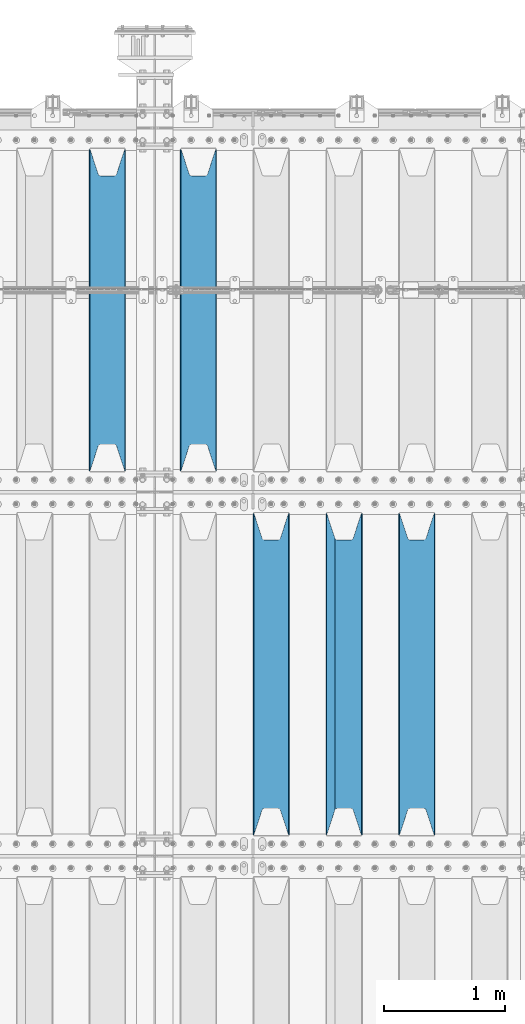
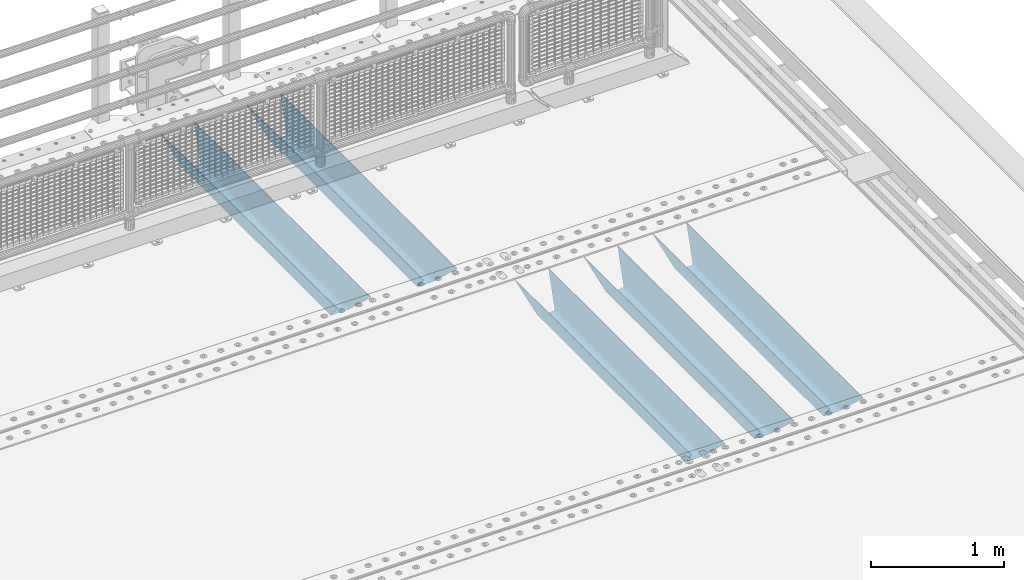
# One storey, part 123 of 240: 5 beams.
"""IFC2X3 building model written with IfcOpenShell, lengths in millimetres."""

import ifcopenshell
import ifcopenshell.guid

model = None  # the IFC model being written
_history = None  # IfcOwnerHistory: only IFC2X3 demands one
_inside = {}  # id of a spatial element -> (the spatial element, [elements in it])
_under = {}  # id of a project, library or spatial element -> (it, [spatial elements below it])
_declared = {}  # id of a project -> (the project, [libraries it declares])
_typed = {}  # id of a type object -> (the type object, [elements of that type])
_made_of = {}  # id of a material, layer set ... -> (it, [elements and type objects made of it])


def new_model(schema):
    """Start an empty IFC model of exactly this schema.

    Asked for "IFC4X3", IfcOpenShell would pick the latest addendum, in which some entities
    have other attributes; the version numbers below select the first issue.
    IFC2X3 requires an IfcOwnerHistory on every rooted entity: one is made here for all.
    """
    global model, _history
    if schema == "IFC4X3":
        model = ifcopenshell.file(schema_version=(4, 3, 0, 0))
    else:
        model = ifcopenshell.file(schema=schema)
    _inside.clear()
    _under.clear()
    _declared.clear()
    _typed.clear()
    _made_of.clear()
    _history = None
    if model.schema == "IFC2X3":
        org = make("IfcOrganization", Name="unknown")
        user = make(
            "IfcPersonAndOrganization",
            ThePerson=make("IfcPerson", FamilyName="unknown"),
            TheOrganization=org,
        )
        app = make(
            "IfcApplication",
            ApplicationDeveloper=org,
            Version="unknown",
            ApplicationFullName="unknown",
            ApplicationIdentifier="unknown",
        )
        _history = make(
            "IfcOwnerHistory",
            OwningUser=user,
            OwningApplication=app,
            ChangeAction="ADDED",
            CreationDate=0,
        )
    return model


def make(cls, **values):
    """One entity of the class cls with the attributes given. An attribute that is None is left unset."""
    return model.create_entity(
        cls, **{name: value for name, value in values.items() if value is not None}
    )


def rooted(cls, **values):
    """An entity with a GlobalId (a new one), such as an element, a storey or a relation."""
    return make(cls, GlobalId=ifcopenshell.guid.new(), OwnerHistory=_history, **values)


def si_unit(unit_type, name, prefix=None):
    """IfcSIUnit, for example si_unit("LENGTHUNIT", "METRE", prefix="MILLI")."""
    return make("IfcSIUnit", UnitType=unit_type, Prefix=prefix, Name=name)


def assignment(units):
    """IfcUnitAssignment: the units of a project."""
    return None if units is None else make("IfcUnitAssignment", Units=units)


def point(xyz):
    """IfcCartesianPoint."""
    return None if xyz is None else make("IfcCartesianPoint", Coordinates=xyz)


def direction(xyz):
    """IfcDirection."""
    return None if xyz is None else make("IfcDirection", DirectionRatios=xyz)


def frame(location, z_axis=None, x_axis=None):
    """IfcAxis2Placement3D, a coordinate frame: its origin and axes. An axis left out is left unset."""
    return make(
        "IfcAxis2Placement3D",
        Location=point(location),
        Axis=direction(z_axis),
        RefDirection=direction(x_axis),
    )


def origin_with_axes():
    """The frame at (0, 0, 0) with the z axis (0, 0, 1) and the x axis (1, 0, 0) written out."""
    return frame((0.0, 0.0, 0.0), z_axis=(0.0, 0.0, 1.0), x_axis=(1.0, 0.0, 0.0))


def place(relative_to, where):
    """IfcLocalPlacement: puts the frame where relative to a parent placement (None: the world)."""
    return make(
        "IfcLocalPlacement", PlacementRelTo=relative_to, RelativePlacement=where
    )


def context(
    kind, dimensions, precision=None, world=None, true_north=None, identifier=None
):
    """IfcGeometricRepresentationContext, for example the 3D "Model" context."""
    return make(
        "IfcGeometricRepresentationContext",
        ContextIdentifier=identifier,
        ContextType=kind,
        CoordinateSpaceDimension=dimensions,
        Precision=precision,
        WorldCoordinateSystem=world,
        TrueNorth=true_north,
    )


def subcontext(parent, identifier, kind, view, scale=None):
    """IfcGeometricRepresentationSubContext, for example "Body" below "Model"."""
    return make(
        "IfcGeometricRepresentationSubContext",
        ContextIdentifier=identifier,
        ContextType=kind,
        ParentContext=parent,
        TargetScale=scale,
        TargetView=view,
    )


def project(units=None, contexts=None):
    """IfcProject with its units and contexts."""
    return rooted(
        "IfcProject",
        Name="project",
        RepresentationContexts=contexts,
        UnitsInContext=assignment(units),
    )


def spatial(cls, under=None, at=None, **own):
    """A site, building, storey or space (cls), placed at a placement, below another one or the project."""
    s = rooted(cls, ObjectPlacement=at, **own)
    if under is not None:
        _under.setdefault(under.id(), (under, []))[1].append(s)
    return s


def faces_of(points, faces, orient=None, outer=None):
    """IfcFace entities. A face is a list of loops; a loop is a list of indices into points, from 0.

    orient and outer hold one flag for each loop. By default every Orientation is true, the
    first loop of a face is its IfcFaceOuterBound and the others are IfcFaceBound.
    """
    made = []
    for i, loops in enumerate(faces):
        bounds = []
        for j, loop in enumerate(loops):
            is_outer = j == 0 if outer is None else outer[i][j]
            bounds.append(
                make(
                    "IfcFaceOuterBound" if is_outer else "IfcFaceBound",
                    Bound=make("IfcPolyLoop", Polygon=[points[k] for k in loop]),
                    Orientation=True if orient is None else orient[i][j],
                )
            )
        made.append(make("IfcFace", Bounds=bounds))
    return made


def faceted_brep(points, faces, orient=None, outer=None, voids=None):
    """IfcFacetedBrep: a solid bounded by flat faces; with voids (closed shells), ...WithVoids."""
    shared = [point(p) for p in points]
    hull = make("IfcClosedShell", CfsFaces=faces_of(shared, faces, orient, outer))
    if voids is None:
        return make("IfcFacetedBrep", Outer=hull)
    return make(
        "IfcFacetedBrepWithVoids",
        Outer=hull,
        Voids=[
            make(cls, CfsFaces=faces_of(shared, fs, o, b)) for cls, fs, o, b in voids
        ],
    )


def shape(context_of_items, identifier, shape_type, items):
    """IfcShapeRepresentation: the items that make up one representation, for example the "Body"."""
    return make(
        "IfcShapeRepresentation",
        ContextOfItems=context_of_items,
        RepresentationIdentifier=identifier,
        RepresentationType=shape_type,
        Items=items,
    )


def material(Name=None, Category=None):
    """IfcMaterial."""
    return make("IfcMaterial", Name=Name, Category=Category)


def made_of(thing, what):
    """Note that an element or type object is made of a material, layer set ...; save() writes the relation."""
    if what is not None:
        _made_of.setdefault(what.id(), (what, []))[1].append(thing)
    return thing


def type_object(cls, material=None, **own):
    """A type object (cls), such as IfcWallType, which elements share."""
    return made_of(rooted(cls, **own), material)


def element(
    cls,
    number,
    at=None,
    inside=None,
    cuts=None,
    type_object=None,
    material=None,
    context=None,
    identifier="Body",
    shape_type=None,
    held_by="IfcProductDefinitionShape",
    body=None,
    shapes=None,
    **own,
):
    """One element of the class cls, such as IfcWall. Its Tag is "e" and its number.

    at: its placement. inside: the storey or other place that contains it. cuts: it is an
    opening in that element (IfcRelVoidsElement). A single representation is given by context,
    identifier, shape_type and body (its items); several are given by shapes. held_by: the class
    of the entity that holds the representations. save() writes the other relations.
    """
    e = rooted(cls, Tag="e%d" % number, ObjectPlacement=at, **own)
    if body is not None:
        shapes = [shape(context, identifier, shape_type, body)]
    if shapes is not None:
        e.Representation = make(held_by, Representations=shapes)
    if inside is not None:
        _inside.setdefault(inside.id(), (inside, []))[1].append(e)
    if cuts is not None:
        rooted(
            "IfcRelVoidsElement", RelatingBuildingElement=cuts, RelatedOpeningElement=e
        )
    if type_object is not None:
        _typed.setdefault(type_object.id(), (type_object, []))[1].append(e)
    return made_of(e, material)


def aggregate(whole, parts):
    """IfcRelAggregates: a whole, such as a stair, and the parts it consists of."""
    return rooted("IfcRelAggregates", RelatingObject=whole, RelatedObjects=parts)


def save(model, path):
    """Write the relations noted so far, then the file.

    IfcRelAggregates (storeys below a building ...), IfcRelContainedInSpatialStructure (elements
    in a storey), IfcRelDefinesByType, IfcRelAssociatesMaterial and IfcRelDeclares: one each for
    every whole, place, type object, material and project.
    """
    for whole, parts in _under.values():
        aggregate(whole, parts)
    for where, things in _inside.values():
        rooted(
            "IfcRelContainedInSpatialStructure",
            RelatedElements=things,
            RelatingStructure=where,
        )
    for kind, things in _typed.values():
        rooted("IfcRelDefinesByType", RelatedObjects=things, RelatingType=kind)
    for what, things in _made_of.values():
        rooted("IfcRelAssociatesMaterial", RelatedObjects=things, RelatingMaterial=what)
    for by, libraries in _declared.values():
        rooted("IfcRelDeclares", RelatingContext=by, RelatedDefinitions=libraries)
    model.write(path)


model = new_model("IFC2X3")

# Units and contexts
model_context = context("Model", 3, precision=1e-05, world=origin_with_axes())
body_context = subcontext(model_context, "Body", "Model", "MODEL_VIEW")
ifc_project = project(units=[si_unit("LENGTHUNIT", "METRE", prefix="MILLI"), si_unit("AREAUNIT", "SQUARE_METRE"), si_unit("VOLUMEUNIT", "CUBIC_METRE"), si_unit("MASSUNIT", "GRAM", prefix="KILO"), si_unit("TIMEUNIT", "SECOND"), si_unit("PLANEANGLEUNIT", "RADIAN"), si_unit("SOLIDANGLEUNIT", "STERADIAN"), si_unit("THERMODYNAMICTEMPERATUREUNIT", "DEGREE_CELSIUS"), si_unit("LUMINOUSINTENSITYUNIT", "LUMEN")], contexts=[model_context])

# Site, building, storey
site_placement = place(None, origin_with_axes())
site = spatial("IfcSite", under=ifc_project, at=site_placement, CompositionType="ELEMENT")
building_placement = place(site_placement, origin_with_axes())
building = spatial("IfcBuilding", under=site, at=building_placement, Name="Standard", CompositionType="ELEMENT")
storey_placement = place(building_placement, origin_with_axes())
storey = spatial("IfcBuildingStorey", under=building, at=storey_placement, Name="Undefined", CompositionType="ELEMENT", Elevation=0.0)

# Beams
ifc_material = material(Name="STEEL/S355N")
beam_type = type_object("IfcBeamType", PredefinedType="NOTDEFINED")
beam_1_placement = place(storey_placement, frame((55000.0, 30175.0, -115.0), z_axis=(0.0, 0.0, 1.0), x_axis=(0.0, 1.0, 0.0)))
element("IfcBeam", 1, at=beam_1_placement, inside=storey, type_object=beam_type, material=ifc_material, context=body_context, shape_type="Brep", body=[
    faceted_brep([(0.0, 150.0, 115.0), (0.0, 143.690000000002, 115.0), (2650.00000000297, 143.690000000002, 115.0), (2650.00000000297, 150.0, 115.0), (2650.00000000297, 142.059565218406, 110.000000003094), (2650.00000000297, 148.369565218403, 110.000000003094), (2441.90079219209, -80.1103600731149, -98.0992078077845), (2437.7588105432, -77.5672621345584, -102.241189456673), (2434.06523489747, -74.4080125315522, -105.934765102404), (2430.9108609509, -70.7102721255724, -109.089139048974), (2428.37322971128, -66.5649389910031, -111.626770288588), (2426.51472138055, -62.0739139532889, -113.485278619323), (2425.38102192092, -57.3475956567636, -114.618978078955), (2424.99999999987, -52.5021667386536, -115.0), (2424.99999999987, 52.5021667386536, -115.0), (2425.38102192092, 57.3475956567636, -114.618978078955), (2426.51472138055, 62.0739139532889, -113.485278619323), (2428.37322971128, 66.5649389910031, -111.626770288588), (2430.9108609509, 70.7102721255724, -109.089139048974), (2434.06523489747, 74.4080125315522, -105.934765102404), (2437.7588105432, 77.5672621345584, -102.241189456673), (2441.90079219209, 80.1103600731149, -98.0992078077846), (2446.38936140512, 81.9747917625791, -93.6106385947584), (2448.2494850041, 76.2713538057287, -91.7505149957729), (2444.62967112263, 74.76777986261, -95.3703288772456), (2441.28936334127, 72.7168944282894, -98.710636658607), (2438.31067330439, 70.1691124903809, -101.689326695487), (2435.76682334748, 67.1870637758839, -104.233176652398), (2433.72034654134, 63.8440531834931, -106.279653458539), (2432.22154950042, 60.2222587982324, -107.778450499454), (2431.30727574265, 56.4107117849126, -108.692724257221), (2430.99999999987, 52.5031078186876, -109.0), (2430.99999999987, -52.5031078186876, -109.0), (2431.30727574265, -56.4107117849126, -108.692724257221), (2432.22154950042, -60.2222587982324, -107.778450499454), (2433.72034654134, -63.8440531834931, -106.279653458539), (2435.76682334748, -67.1870637758839, -104.233176652398), (2438.31067330439, -70.1691124903809, -101.689326695487), (2441.28936334127, -72.7168944282894, -98.7106366586071), (2444.62967112263, -74.76777986261, -95.3703288772457), (2448.2494850041, -76.2713538057287, -91.7505149957729), (2650.00000000297, -142.059565218406, 110.000000003094), (2650.00000000297, -148.369565218403, 110.000000003094), (2446.38936140512, -81.9747917625791, -93.6106385947584), (2650.00000000297, -143.690000000002, 115.0), (2650.00000000297, -150.0, 115.0), (0.0, -143.690000000002, 115.0), (0.0, -150.0, 115.0), (0.0, -148.369565218258, 110.000000002667), (203.610638597427, -81.9747917625791, -93.6106385947584), (208.09920781045, -80.1103600731149, -98.0992078077845), (212.241189459342, -77.5672621345584, -102.241189456673), (215.93476510507, -74.4080125315522, -105.934765102404), (219.089139051641, -70.7102721255724, -109.089139048974), (221.626770291256, -66.5649389910031, -111.626770288588), (223.485278621989, -62.0739139532889, -113.485278619323), (224.618978081624, -57.3475956567636, -114.618978078955), (225.000000002663, -52.5021667386536, -115.0), (225.000000002663, 52.5021667386536, -115.0), (224.618978081624, 57.3475956567636, -114.618978078955), (223.485278621989, 62.0739139532889, -113.485278619323), (221.626770291256, 66.5649389910031, -111.626770288588), (219.089139051641, 70.7102721255724, -109.089139048974), (215.93476510507, 74.4080125315522, -105.934765102404), (212.241189459342, 77.5672621345584, -102.241189456673), (208.09920781045, 80.1103600731149, -98.0992078077846), (203.610638597427, 81.9747917625791, -93.6106385947584), (0.0, 148.369565218258, 110.000000002667), (0.0, 142.05956521826, 110.000000002667), (201.750514998439, 76.2713538057287, -91.7505149957729), (205.370328879908, 74.76777986261, -95.3703288772456), (208.710636661275, 72.7168944282894, -98.710636658607), (211.689326698153, 70.1691124903809, -101.689326695487), (214.233176655063, 67.1870637758839, -104.233176652398), (216.279653461206, 63.8440531834931, -106.279653458539), (217.778450502123, 60.2222587982324, -107.778450499454), (218.692724259887, 56.4107117849126, -108.692724257221), (219.000000002667, 52.5031078186876, -109.0), (219.000000002667, -52.5031078186876, -109.0), (218.692724259887, -56.4107117849126, -108.692724257221), (217.778450502123, -60.2222587982324, -107.778450499454), (216.279653461206, -63.8440531834931, -106.279653458539), (214.233176655063, -67.1870637758839, -104.233176652398), (211.689326698153, -70.1691124903809, -101.689326695487), (208.710636661275, -72.7168944282894, -98.7106366586071), (205.370328879915, -74.76777986261, -95.3703288772457), (201.750514998439, -76.2713538057287, -91.7505149957729), (0.0, -142.05956521826, 110.000000002667)], [[[0, 1, 2, 3]], [[3, 2, 4, 5]], [[6, 7, 8, 9, 10, 11, 12, 13, 14, 15, 16, 17, 18, 19, 20, 21, 22, 5, 4, 23, 24, 25, 26, 27, 28, 29, 30, 31, 32, 33, 34, 35, 36, 37, 38, 39, 40, 41, 42, 43]], [[44, 45, 42, 41]], [[46, 47, 45, 44]], [[43, 42, 45, 47, 48, 49]], [[6, 43, 49, 50]], [[7, 6, 50, 51]], [[8, 7, 51, 52]], [[9, 8, 52, 53]], [[10, 9, 53, 54]], [[11, 10, 54, 55]], [[12, 11, 55, 56]], [[13, 12, 56, 57]], [[14, 13, 57, 58]], [[15, 14, 58, 59]], [[16, 15, 59, 60]], [[17, 16, 60, 61]], [[18, 17, 61, 62]], [[19, 18, 62, 63]], [[20, 19, 63, 64]], [[21, 20, 64, 65]], [[22, 21, 65, 66]], [[0, 3, 5, 22, 66, 67]], [[1, 0, 67, 68]], [[23, 4, 2, 1, 68, 69]], [[24, 23, 69, 70]], [[25, 24, 70, 71]], [[26, 25, 71, 72]], [[27, 26, 72, 73]], [[28, 27, 73, 74]], [[29, 28, 74, 75]], [[30, 29, 75, 76]], [[31, 30, 76, 77]], [[32, 31, 77, 78]], [[33, 32, 78, 79]], [[34, 33, 79, 80]], [[35, 34, 80, 81]], [[36, 35, 81, 82]], [[37, 36, 82, 83]], [[38, 37, 83, 84]], [[39, 38, 84, 85]], [[40, 39, 85, 86]], [[46, 44, 41, 40, 86, 87]], [[47, 46, 87, 48]], [[86, 85, 84, 83, 82, 81, 80, 79, 78, 77, 76, 75, 74, 73, 72, 71, 70, 69, 68, 67, 66, 65, 64, 63, 62, 61, 60, 59, 58, 57, 56, 55, 54, 53, 52, 51, 50, 49, 48, 87]]]),
])
beam_2_placement = place(storey_placement, frame((54400.0, 30175.0, -115.0), z_axis=(0.0, 0.0, 1.0), x_axis=(0.0, 1.0, 0.0)))
element("IfcBeam", 2, at=beam_2_placement, inside=storey, type_object=beam_type, material=ifc_material, context=body_context, shape_type="Brep", body=[
    faceted_brep([(0.0, 150.0, 115.0), (0.0, 143.690000000002, 115.0), (2650.00000000297, 143.690000000002, 115.0), (2650.00000000297, 150.0, 115.0), (2650.00000000297, 142.059565218406, 110.000000003094), (2650.00000000297, 148.369565218403, 110.000000003094), (2441.90079219209, -80.1103600731149, -98.0992078077845), (2437.7588105432, -77.5672621345584, -102.241189456673), (2434.06523489747, -74.4080125315522, -105.934765102404), (2430.9108609509, -70.7102721255724, -109.089139048974), (2428.37322971128, -66.5649389910031, -111.626770288588), (2426.51472138055, -62.0739139532889, -113.485278619323), (2425.38102192092, -57.3475956567636, -114.618978078955), (2424.99999999987, -52.5021667386536, -115.0), (2424.99999999987, 52.5021667386536, -115.0), (2425.38102192092, 57.3475956567636, -114.618978078955), (2426.51472138055, 62.0739139532889, -113.485278619323), (2428.37322971128, 66.5649389910031, -111.626770288588), (2430.9108609509, 70.7102721255724, -109.089139048974), (2434.06523489747, 74.4080125315522, -105.934765102404), (2437.7588105432, 77.5672621345584, -102.241189456673), (2441.90079219209, 80.1103600731149, -98.0992078077846), (2446.38936140512, 81.9747917625791, -93.6106385947584), (2448.2494850041, 76.2713538057287, -91.7505149957729), (2444.62967112263, 74.76777986261, -95.3703288772456), (2441.28936334127, 72.7168944282894, -98.710636658607), (2438.31067330439, 70.1691124903809, -101.689326695487), (2435.76682334748, 67.1870637758839, -104.233176652398), (2433.72034654134, 63.8440531834931, -106.279653458539), (2432.22154950042, 60.2222587982324, -107.778450499454), (2431.30727574265, 56.4107117849126, -108.692724257221), (2430.99999999987, 52.5031078186876, -109.0), (2430.99999999987, -52.5031078186876, -109.0), (2431.30727574265, -56.4107117849126, -108.692724257221), (2432.22154950042, -60.2222587982324, -107.778450499454), (2433.72034654134, -63.8440531834931, -106.279653458539), (2435.76682334748, -67.1870637758839, -104.233176652398), (2438.31067330439, -70.1691124903809, -101.689326695487), (2441.28936334127, -72.7168944282894, -98.7106366586071), (2444.62967112263, -74.76777986261, -95.3703288772457), (2448.2494850041, -76.2713538057287, -91.7505149957729), (2650.00000000297, -142.059565218406, 110.000000003094), (2650.00000000297, -148.369565218403, 110.000000003094), (2446.38936140512, -81.9747917625791, -93.6106385947584), (2650.00000000297, -143.690000000002, 115.0), (2650.00000000297, -150.0, 115.0), (0.0, -143.690000000002, 115.0), (0.0, -150.0, 115.0), (0.0, -148.369565218258, 110.000000002667), (203.610638597427, -81.9747917625791, -93.6106385947584), (208.09920781045, -80.1103600731149, -98.0992078077845), (212.241189459342, -77.5672621345584, -102.241189456673), (215.93476510507, -74.4080125315522, -105.934765102404), (219.089139051641, -70.7102721255724, -109.089139048974), (221.626770291256, -66.5649389910031, -111.626770288588), (223.485278621989, -62.0739139532889, -113.485278619323), (224.618978081624, -57.3475956567636, -114.618978078955), (225.000000002663, -52.5021667386536, -115.0), (225.000000002663, 52.5021667386536, -115.0), (224.618978081624, 57.3475956567636, -114.618978078955), (223.485278621989, 62.0739139532889, -113.485278619323), (221.626770291256, 66.5649389910031, -111.626770288588), (219.089139051641, 70.7102721255724, -109.089139048974), (215.93476510507, 74.4080125315522, -105.934765102404), (212.241189459342, 77.5672621345584, -102.241189456673), (208.09920781045, 80.1103600731149, -98.0992078077846), (203.610638597427, 81.9747917625791, -93.6106385947584), (0.0, 148.369565218258, 110.000000002667), (0.0, 142.05956521826, 110.000000002667), (201.750514998439, 76.2713538057287, -91.7505149957729), (205.370328879908, 74.76777986261, -95.3703288772456), (208.710636661275, 72.7168944282894, -98.710636658607), (211.689326698153, 70.1691124903809, -101.689326695487), (214.233176655063, 67.1870637758839, -104.233176652398), (216.279653461206, 63.8440531834931, -106.279653458539), (217.778450502123, 60.2222587982324, -107.778450499454), (218.692724259887, 56.4107117849126, -108.692724257221), (219.000000002667, 52.5031078186876, -109.0), (219.000000002667, -52.5031078186876, -109.0), (218.692724259887, -56.4107117849126, -108.692724257221), (217.778450502123, -60.2222587982324, -107.778450499454), (216.279653461206, -63.8440531834931, -106.279653458539), (214.233176655063, -67.1870637758839, -104.233176652398), (211.689326698153, -70.1691124903809, -101.689326695487), (208.710636661275, -72.7168944282894, -98.7106366586071), (205.370328879915, -74.76777986261, -95.3703288772457), (201.750514998439, -76.2713538057287, -91.7505149957729), (0.0, -142.05956521826, 110.000000002667)], [[[0, 1, 2, 3]], [[3, 2, 4, 5]], [[6, 7, 8, 9, 10, 11, 12, 13, 14, 15, 16, 17, 18, 19, 20, 21, 22, 5, 4, 23, 24, 25, 26, 27, 28, 29, 30, 31, 32, 33, 34, 35, 36, 37, 38, 39, 40, 41, 42, 43]], [[44, 45, 42, 41]], [[46, 47, 45, 44]], [[43, 42, 45, 47, 48, 49]], [[6, 43, 49, 50]], [[7, 6, 50, 51]], [[8, 7, 51, 52]], [[9, 8, 52, 53]], [[10, 9, 53, 54]], [[11, 10, 54, 55]], [[12, 11, 55, 56]], [[13, 12, 56, 57]], [[14, 13, 57, 58]], [[15, 14, 58, 59]], [[16, 15, 59, 60]], [[17, 16, 60, 61]], [[18, 17, 61, 62]], [[19, 18, 62, 63]], [[20, 19, 63, 64]], [[21, 20, 64, 65]], [[22, 21, 65, 66]], [[0, 3, 5, 22, 66, 67]], [[1, 0, 67, 68]], [[23, 4, 2, 1, 68, 69]], [[24, 23, 69, 70]], [[25, 24, 70, 71]], [[26, 25, 71, 72]], [[27, 26, 72, 73]], [[28, 27, 73, 74]], [[29, 28, 74, 75]], [[30, 29, 75, 76]], [[31, 30, 76, 77]], [[32, 31, 77, 78]], [[33, 32, 78, 79]], [[34, 33, 79, 80]], [[35, 34, 80, 81]], [[36, 35, 81, 82]], [[37, 36, 82, 83]], [[38, 37, 83, 84]], [[39, 38, 84, 85]], [[40, 39, 85, 86]], [[46, 44, 41, 40, 86, 87]], [[47, 46, 87, 48]], [[86, 85, 84, 83, 82, 81, 80, 79, 78, 77, 76, 75, 74, 73, 72, 71, 70, 69, 68, 67, 66, 65, 64, 63, 62, 61, 60, 59, 58, 57, 56, 55, 54, 53, 52, 51, 50, 49, 48, 87]]]),
])
beam_3_placement = place(storey_placement, frame((53800.0, 30175.0, -115.0), z_axis=(0.0, 0.0, 1.0), x_axis=(0.0, 1.0, 0.0)))
element("IfcBeam", 3, at=beam_3_placement, inside=storey, type_object=beam_type, material=ifc_material, context=body_context, shape_type="Brep", body=[
    faceted_brep([(0.0, 150.0, 115.0), (0.0, 143.690000000002, 115.0), (2650.00000000297, 143.690000000002, 115.0), (2650.00000000297, 150.0, 115.0), (2650.00000000297, 142.059565218406, 110.000000003094), (2650.00000000297, 148.369565218403, 110.000000003094), (2441.90079219209, -80.1103600731149, -98.0992078077845), (2437.7588105432, -77.5672621345584, -102.241189456673), (2434.06523489747, -74.4080125315522, -105.934765102404), (2430.9108609509, -70.7102721255724, -109.089139048974), (2428.37322971128, -66.5649389910031, -111.626770288588), (2426.51472138055, -62.0739139532889, -113.485278619323), (2425.38102192092, -57.3475956567636, -114.618978078955), (2424.99999999987, -52.5021667386536, -115.0), (2424.99999999987, 52.5021667386536, -115.0), (2425.38102192092, 57.3475956567636, -114.618978078955), (2426.51472138055, 62.0739139532889, -113.485278619323), (2428.37322971128, 66.5649389910031, -111.626770288588), (2430.9108609509, 70.7102721255724, -109.089139048974), (2434.06523489747, 74.4080125315522, -105.934765102404), (2437.7588105432, 77.5672621345584, -102.241189456673), (2441.90079219209, 80.1103600731149, -98.0992078077846), (2446.38936140512, 81.9747917625791, -93.6106385947584), (2448.2494850041, 76.2713538057287, -91.7505149957729), (2444.62967112263, 74.76777986261, -95.3703288772456), (2441.28936334127, 72.7168944282894, -98.710636658607), (2438.31067330439, 70.1691124903809, -101.689326695487), (2435.76682334748, 67.1870637758839, -104.233176652398), (2433.72034654134, 63.8440531834931, -106.279653458539), (2432.22154950042, 60.2222587982324, -107.778450499454), (2431.30727574265, 56.4107117849126, -108.692724257221), (2430.99999999987, 52.5031078186876, -109.0), (2430.99999999987, -52.5031078186876, -109.0), (2431.30727574265, -56.4107117849126, -108.692724257221), (2432.22154950042, -60.2222587982324, -107.778450499454), (2433.72034654134, -63.8440531834931, -106.279653458539), (2435.76682334748, -67.1870637758839, -104.233176652398), (2438.31067330439, -70.1691124903809, -101.689326695487), (2441.28936334127, -72.7168944282894, -98.7106366586071), (2444.62967112263, -74.76777986261, -95.3703288772457), (2448.2494850041, -76.2713538057287, -91.7505149957729), (2650.00000000297, -142.059565218406, 110.000000003094), (2650.00000000297, -148.369565218403, 110.000000003094), (2446.38936140512, -81.9747917625791, -93.6106385947584), (2650.00000000297, -143.690000000002, 115.0), (2650.00000000297, -150.0, 115.0), (0.0, -143.690000000002, 115.0), (0.0, -150.0, 115.0), (0.0, -148.369565218258, 110.000000002667), (203.610638597427, -81.9747917625791, -93.6106385947584), (208.09920781045, -80.1103600731149, -98.0992078077845), (212.241189459342, -77.5672621345584, -102.241189456673), (215.93476510507, -74.4080125315522, -105.934765102404), (219.089139051641, -70.7102721255724, -109.089139048974), (221.626770291256, -66.5649389910031, -111.626770288588), (223.485278621989, -62.0739139532889, -113.485278619323), (224.618978081624, -57.3475956567636, -114.618978078955), (225.000000002663, -52.5021667386536, -115.0), (225.000000002663, 52.5021667386536, -115.0), (224.618978081624, 57.3475956567636, -114.618978078955), (223.485278621989, 62.0739139532889, -113.485278619323), (221.626770291256, 66.5649389910031, -111.626770288588), (219.089139051641, 70.7102721255724, -109.089139048974), (215.93476510507, 74.4080125315522, -105.934765102404), (212.241189459342, 77.5672621345584, -102.241189456673), (208.09920781045, 80.1103600731149, -98.0992078077846), (203.610638597427, 81.9747917625791, -93.6106385947584), (0.0, 148.369565218258, 110.000000002667), (0.0, 142.05956521826, 110.000000002667), (201.750514998439, 76.2713538057287, -91.7505149957729), (205.370328879908, 74.76777986261, -95.3703288772456), (208.710636661275, 72.7168944282894, -98.710636658607), (211.689326698153, 70.1691124903809, -101.689326695487), (214.233176655063, 67.1870637758839, -104.233176652398), (216.279653461206, 63.8440531834931, -106.279653458539), (217.778450502123, 60.2222587982324, -107.778450499454), (218.692724259887, 56.4107117849126, -108.692724257221), (219.000000002667, 52.5031078186876, -109.0), (219.000000002667, -52.5031078186876, -109.0), (218.692724259887, -56.4107117849126, -108.692724257221), (217.778450502123, -60.2222587982324, -107.778450499454), (216.279653461206, -63.8440531834931, -106.279653458539), (214.233176655063, -67.1870637758839, -104.233176652398), (211.689326698153, -70.1691124903809, -101.689326695487), (208.710636661275, -72.7168944282894, -98.7106366586071), (205.370328879915, -74.76777986261, -95.3703288772457), (201.750514998439, -76.2713538057287, -91.7505149957729), (0.0, -142.05956521826, 110.000000002667)], [[[0, 1, 2, 3]], [[3, 2, 4, 5]], [[6, 7, 8, 9, 10, 11, 12, 13, 14, 15, 16, 17, 18, 19, 20, 21, 22, 5, 4, 23, 24, 25, 26, 27, 28, 29, 30, 31, 32, 33, 34, 35, 36, 37, 38, 39, 40, 41, 42, 43]], [[44, 45, 42, 41]], [[46, 47, 45, 44]], [[43, 42, 45, 47, 48, 49]], [[6, 43, 49, 50]], [[7, 6, 50, 51]], [[8, 7, 51, 52]], [[9, 8, 52, 53]], [[10, 9, 53, 54]], [[11, 10, 54, 55]], [[12, 11, 55, 56]], [[13, 12, 56, 57]], [[14, 13, 57, 58]], [[15, 14, 58, 59]], [[16, 15, 59, 60]], [[17, 16, 60, 61]], [[18, 17, 61, 62]], [[19, 18, 62, 63]], [[20, 19, 63, 64]], [[21, 20, 64, 65]], [[22, 21, 65, 66]], [[0, 3, 5, 22, 66, 67]], [[1, 0, 67, 68]], [[23, 4, 2, 1, 68, 69]], [[24, 23, 69, 70]], [[25, 24, 70, 71]], [[26, 25, 71, 72]], [[27, 26, 72, 73]], [[28, 27, 73, 74]], [[29, 28, 74, 75]], [[30, 29, 75, 76]], [[31, 30, 76, 77]], [[32, 31, 77, 78]], [[33, 32, 78, 79]], [[34, 33, 79, 80]], [[35, 34, 80, 81]], [[36, 35, 81, 82]], [[37, 36, 82, 83]], [[38, 37, 83, 84]], [[39, 38, 84, 85]], [[40, 39, 85, 86]], [[46, 44, 41, 40, 86, 87]], [[47, 46, 87, 48]], [[86, 85, 84, 83, 82, 81, 80, 79, 78, 77, 76, 75, 74, 73, 72, 71, 70, 69, 68, 67, 66, 65, 64, 63, 62, 61, 60, 59, 58, 57, 56, 55, 54, 53, 52, 51, 50, 49, 48, 87]]]),
])
beam_4_placement = place(storey_placement, frame((53200.0, 33175.0, -115.0), z_axis=(0.0, 0.0, 1.0), x_axis=(0.0, 1.0, 0.0)))
element("IfcBeam", 4, at=beam_4_placement, inside=storey, type_object=beam_type, material=ifc_material, context=body_context, shape_type="Brep", body=[
    faceted_brep([(0.0, 150.0, 115.0), (0.0, 143.690000000002, 115.0), (2650.00000000297, 143.690000000002, 115.0), (2650.00000000297, 150.0, 115.0), (2650.00000000297, 142.059565218406, 110.000000003094), (2650.00000000297, 148.369565218403, 110.000000003094), (2441.90079219209, -80.1103600731149, -98.0992078077845), (2437.7588105432, -77.5672621345584, -102.241189456673), (2434.06523489747, -74.4080125315522, -105.934765102404), (2430.9108609509, -70.7102721255724, -109.089139048974), (2428.37322971128, -66.5649389910031, -111.626770288588), (2426.51472138055, -62.0739139532889, -113.485278619323), (2425.38102192092, -57.3475956567636, -114.618978078955), (2424.99999999987, -52.5021667386536, -115.0), (2424.99999999987, 52.5021667386536, -115.0), (2425.38102192092, 57.3475956567636, -114.618978078955), (2426.51472138055, 62.0739139532889, -113.485278619323), (2428.37322971128, 66.5649389910031, -111.626770288588), (2430.9108609509, 70.7102721255724, -109.089139048974), (2434.06523489747, 74.4080125315522, -105.934765102404), (2437.7588105432, 77.5672621345584, -102.241189456673), (2441.90079219209, 80.1103600731149, -98.0992078077846), (2446.38936140512, 81.9747917625791, -93.6106385947584), (2448.2494850041, 76.2713538057287, -91.7505149957729), (2444.62967112263, 74.76777986261, -95.3703288772456), (2441.28936334127, 72.7168944282894, -98.710636658607), (2438.31067330439, 70.1691124903809, -101.689326695487), (2435.76682334748, 67.1870637758839, -104.233176652398), (2433.72034654134, 63.8440531834931, -106.279653458539), (2432.22154950042, 60.2222587982324, -107.778450499454), (2431.30727574265, 56.4107117849126, -108.692724257221), (2430.99999999987, 52.5031078186876, -109.0), (2430.99999999987, -52.5031078186876, -109.0), (2431.30727574265, -56.4107117849126, -108.692724257221), (2432.22154950042, -60.2222587982324, -107.778450499454), (2433.72034654134, -63.8440531834931, -106.279653458539), (2435.76682334748, -67.1870637758839, -104.233176652398), (2438.31067330439, -70.1691124903809, -101.689326695487), (2441.28936334127, -72.7168944282894, -98.7106366586071), (2444.62967112263, -74.76777986261, -95.3703288772457), (2448.2494850041, -76.2713538057287, -91.7505149957729), (2650.00000000297, -142.059565218406, 110.000000003094), (2650.00000000297, -148.369565218403, 110.000000003094), (2446.38936140512, -81.9747917625791, -93.6106385947584), (2650.00000000297, -143.690000000002, 115.0), (2650.00000000297, -150.0, 115.0), (0.0, -143.690000000002, 115.0), (0.0, -150.0, 115.0), (0.0, -148.369565218258, 110.000000002667), (203.610638597427, -81.9747917625791, -93.6106385947584), (208.09920781045, -80.1103600731149, -98.0992078077845), (212.241189459342, -77.5672621345584, -102.241189456673), (215.93476510507, -74.4080125315522, -105.934765102404), (219.089139051641, -70.7102721255724, -109.089139048974), (221.626770291256, -66.5649389910031, -111.626770288588), (223.485278621989, -62.0739139532889, -113.485278619323), (224.618978081624, -57.3475956567636, -114.618978078955), (225.000000002663, -52.5021667386536, -115.0), (225.000000002663, 52.5021667386536, -115.0), (224.618978081624, 57.3475956567636, -114.618978078955), (223.485278621989, 62.0739139532889, -113.485278619323), (221.626770291256, 66.5649389910031, -111.626770288588), (219.089139051641, 70.7102721255724, -109.089139048974), (215.93476510507, 74.4080125315522, -105.934765102404), (212.241189459342, 77.5672621345584, -102.241189456673), (208.09920781045, 80.1103600731149, -98.0992078077846), (203.610638597427, 81.9747917625791, -93.6106385947584), (0.0, 148.369565218258, 110.000000002667), (0.0, 142.05956521826, 110.000000002667), (201.750514998439, 76.2713538057287, -91.7505149957729), (205.370328879908, 74.76777986261, -95.3703288772456), (208.710636661275, 72.7168944282894, -98.710636658607), (211.689326698153, 70.1691124903809, -101.689326695487), (214.233176655063, 67.1870637758839, -104.233176652398), (216.279653461206, 63.8440531834931, -106.279653458539), (217.778450502123, 60.2222587982324, -107.778450499454), (218.692724259887, 56.4107117849126, -108.692724257221), (219.000000002667, 52.5031078186876, -109.0), (219.000000002667, -52.5031078186876, -109.0), (218.692724259887, -56.4107117849126, -108.692724257221), (217.778450502123, -60.2222587982324, -107.778450499454), (216.279653461206, -63.8440531834931, -106.279653458539), (214.233176655063, -67.1870637758839, -104.233176652398), (211.689326698153, -70.1691124903809, -101.689326695487), (208.710636661275, -72.7168944282894, -98.7106366586071), (205.370328879915, -74.76777986261, -95.3703288772457), (201.750514998439, -76.2713538057287, -91.7505149957729), (0.0, -142.05956521826, 110.000000002667)], [[[0, 1, 2, 3]], [[3, 2, 4, 5]], [[6, 7, 8, 9, 10, 11, 12, 13, 14, 15, 16, 17, 18, 19, 20, 21, 22, 5, 4, 23, 24, 25, 26, 27, 28, 29, 30, 31, 32, 33, 34, 35, 36, 37, 38, 39, 40, 41, 42, 43]], [[44, 45, 42, 41]], [[46, 47, 45, 44]], [[43, 42, 45, 47, 48, 49]], [[6, 43, 49, 50]], [[7, 6, 50, 51]], [[8, 7, 51, 52]], [[9, 8, 52, 53]], [[10, 9, 53, 54]], [[11, 10, 54, 55]], [[12, 11, 55, 56]], [[13, 12, 56, 57]], [[14, 13, 57, 58]], [[15, 14, 58, 59]], [[16, 15, 59, 60]], [[17, 16, 60, 61]], [[18, 17, 61, 62]], [[19, 18, 62, 63]], [[20, 19, 63, 64]], [[21, 20, 64, 65]], [[22, 21, 65, 66]], [[0, 3, 5, 22, 66, 67]], [[1, 0, 67, 68]], [[23, 4, 2, 1, 68, 69]], [[24, 23, 69, 70]], [[25, 24, 70, 71]], [[26, 25, 71, 72]], [[27, 26, 72, 73]], [[28, 27, 73, 74]], [[29, 28, 74, 75]], [[30, 29, 75, 76]], [[31, 30, 76, 77]], [[32, 31, 77, 78]], [[33, 32, 78, 79]], [[34, 33, 79, 80]], [[35, 34, 80, 81]], [[36, 35, 81, 82]], [[37, 36, 82, 83]], [[38, 37, 83, 84]], [[39, 38, 84, 85]], [[40, 39, 85, 86]], [[46, 44, 41, 40, 86, 87]], [[47, 46, 87, 48]], [[86, 85, 84, 83, 82, 81, 80, 79, 78, 77, 76, 75, 74, 73, 72, 71, 70, 69, 68, 67, 66, 65, 64, 63, 62, 61, 60, 59, 58, 57, 56, 55, 54, 53, 52, 51, 50, 49, 48, 87]]]),
])
beam_5_placement = place(storey_placement, frame((52450.0, 33175.0, -115.0), z_axis=(0.0, 0.0, 1.0), x_axis=(0.0, 1.0, 0.0)))
element("IfcBeam", 5, at=beam_5_placement, inside=storey, type_object=beam_type, material=ifc_material, context=body_context, shape_type="Brep", body=[
    faceted_brep([(0.0, 150.0, 115.0), (0.0, 143.690000000002, 115.0), (2650.00000000297, 143.690000000002, 115.0), (2650.00000000297, 150.0, 115.0), (2650.00000000297, 142.059565218406, 110.000000003094), (2650.00000000297, 148.369565218403, 110.000000003094), (2441.90079219209, -80.1103600731149, -98.0992078077845), (2437.7588105432, -77.5672621345584, -102.241189456673), (2434.06523489747, -74.4080125315522, -105.934765102404), (2430.9108609509, -70.7102721255724, -109.089139048974), (2428.37322971128, -66.5649389910031, -111.626770288588), (2426.51472138055, -62.0739139532889, -113.485278619323), (2425.38102192092, -57.3475956567636, -114.618978078955), (2424.99999999987, -52.5021667386536, -115.0), (2424.99999999987, 52.5021667386536, -115.0), (2425.38102192092, 57.3475956567636, -114.618978078955), (2426.51472138055, 62.0739139532889, -113.485278619323), (2428.37322971128, 66.5649389910031, -111.626770288588), (2430.9108609509, 70.7102721255724, -109.089139048974), (2434.06523489747, 74.4080125315522, -105.934765102404), (2437.7588105432, 77.5672621345584, -102.241189456673), (2441.90079219209, 80.1103600731149, -98.0992078077846), (2446.38936140512, 81.9747917625791, -93.6106385947584), (2448.2494850041, 76.2713538057287, -91.7505149957729), (2444.62967112263, 74.76777986261, -95.3703288772456), (2441.28936334127, 72.7168944282894, -98.710636658607), (2438.31067330439, 70.1691124903809, -101.689326695487), (2435.76682334748, 67.1870637758839, -104.233176652398), (2433.72034654134, 63.8440531834931, -106.279653458539), (2432.22154950042, 60.2222587982324, -107.778450499454), (2431.30727574265, 56.4107117849126, -108.692724257221), (2430.99999999987, 52.5031078186876, -109.0), (2430.99999999987, -52.5031078186876, -109.0), (2431.30727574265, -56.4107117849126, -108.692724257221), (2432.22154950042, -60.2222587982324, -107.778450499454), (2433.72034654134, -63.8440531834931, -106.279653458539), (2435.76682334748, -67.1870637758839, -104.233176652398), (2438.31067330439, -70.1691124903809, -101.689326695487), (2441.28936334127, -72.7168944282894, -98.7106366586071), (2444.62967112263, -74.76777986261, -95.3703288772457), (2448.2494850041, -76.2713538057287, -91.7505149957729), (2650.00000000297, -142.059565218406, 110.000000003094), (2650.00000000297, -148.369565218403, 110.000000003094), (2446.38936140512, -81.9747917625791, -93.6106385947584), (2650.00000000297, -143.690000000002, 115.0), (2650.00000000297, -150.0, 115.0), (0.0, -143.690000000002, 115.0), (0.0, -150.0, 115.0), (0.0, -148.369565218258, 110.000000002667), (203.610638597427, -81.9747917625791, -93.6106385947584), (208.09920781045, -80.1103600731149, -98.0992078077845), (212.241189459342, -77.5672621345584, -102.241189456673), (215.93476510507, -74.4080125315522, -105.934765102404), (219.089139051641, -70.7102721255724, -109.089139048974), (221.626770291256, -66.5649389910031, -111.626770288588), (223.485278621989, -62.0739139532889, -113.485278619323), (224.618978081624, -57.3475956567636, -114.618978078955), (225.000000002663, -52.5021667386536, -115.0), (225.000000002663, 52.5021667386536, -115.0), (224.618978081624, 57.3475956567636, -114.618978078955), (223.485278621989, 62.0739139532889, -113.485278619323), (221.626770291256, 66.5649389910031, -111.626770288588), (219.089139051641, 70.7102721255724, -109.089139048974), (215.93476510507, 74.4080125315522, -105.934765102404), (212.241189459342, 77.5672621345584, -102.241189456673), (208.09920781045, 80.1103600731149, -98.0992078077846), (203.610638597427, 81.9747917625791, -93.6106385947584), (0.0, 148.369565218258, 110.000000002667), (0.0, 142.05956521826, 110.000000002667), (201.750514998439, 76.2713538057287, -91.7505149957729), (205.370328879908, 74.76777986261, -95.3703288772456), (208.710636661275, 72.7168944282894, -98.710636658607), (211.689326698153, 70.1691124903809, -101.689326695487), (214.233176655063, 67.1870637758839, -104.233176652398), (216.279653461206, 63.8440531834931, -106.279653458539), (217.778450502123, 60.2222587982324, -107.778450499454), (218.692724259887, 56.4107117849126, -108.692724257221), (219.000000002667, 52.5031078186876, -109.0), (219.000000002667, -52.5031078186876, -109.0), (218.692724259887, -56.4107117849126, -108.692724257221), (217.778450502123, -60.2222587982324, -107.778450499454), (216.279653461206, -63.8440531834931, -106.279653458539), (214.233176655063, -67.1870637758839, -104.233176652398), (211.689326698153, -70.1691124903809, -101.689326695487), (208.710636661275, -72.7168944282894, -98.7106366586071), (205.370328879915, -74.76777986261, -95.3703288772457), (201.750514998439, -76.2713538057287, -91.7505149957729), (0.0, -142.05956521826, 110.000000002667)], [[[0, 1, 2, 3]], [[3, 2, 4, 5]], [[6, 7, 8, 9, 10, 11, 12, 13, 14, 15, 16, 17, 18, 19, 20, 21, 22, 5, 4, 23, 24, 25, 26, 27, 28, 29, 30, 31, 32, 33, 34, 35, 36, 37, 38, 39, 40, 41, 42, 43]], [[44, 45, 42, 41]], [[46, 47, 45, 44]], [[43, 42, 45, 47, 48, 49]], [[6, 43, 49, 50]], [[7, 6, 50, 51]], [[8, 7, 51, 52]], [[9, 8, 52, 53]], [[10, 9, 53, 54]], [[11, 10, 54, 55]], [[12, 11, 55, 56]], [[13, 12, 56, 57]], [[14, 13, 57, 58]], [[15, 14, 58, 59]], [[16, 15, 59, 60]], [[17, 16, 60, 61]], [[18, 17, 61, 62]], [[19, 18, 62, 63]], [[20, 19, 63, 64]], [[21, 20, 64, 65]], [[22, 21, 65, 66]], [[0, 3, 5, 22, 66, 67]], [[1, 0, 67, 68]], [[23, 4, 2, 1, 68, 69]], [[24, 23, 69, 70]], [[25, 24, 70, 71]], [[26, 25, 71, 72]], [[27, 26, 72, 73]], [[28, 27, 73, 74]], [[29, 28, 74, 75]], [[30, 29, 75, 76]], [[31, 30, 76, 77]], [[32, 31, 77, 78]], [[33, 32, 78, 79]], [[34, 33, 79, 80]], [[35, 34, 80, 81]], [[36, 35, 81, 82]], [[37, 36, 82, 83]], [[38, 37, 83, 84]], [[39, 38, 84, 85]], [[40, 39, 85, 86]], [[46, 44, 41, 40, 86, 87]], [[47, 46, 87, 48]], [[86, 85, 84, 83, 82, 81, 80, 79, 78, 77, 76, 75, 74, 73, 72, 71, 70, 69, 68, 67, 66, 65, 64, 63, 62, 61, 60, 59, 58, 57, 56, 55, 54, 53, 52, 51, 50, 49, 48, 87]]]),
])

save(model, "model.ifc")
